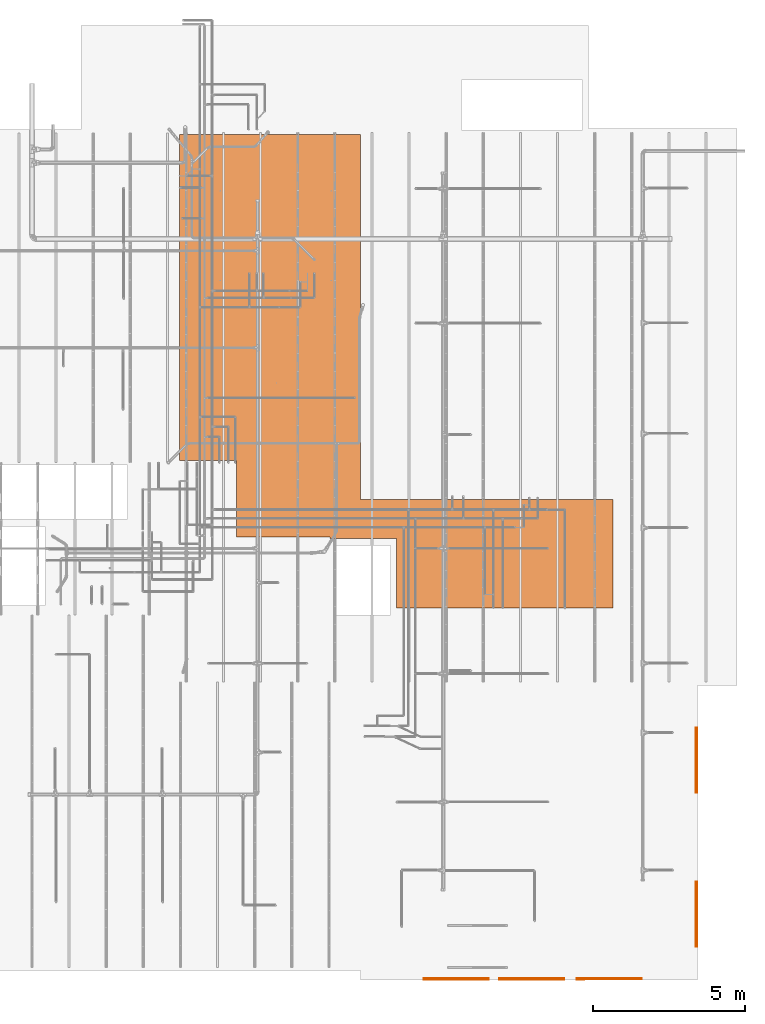
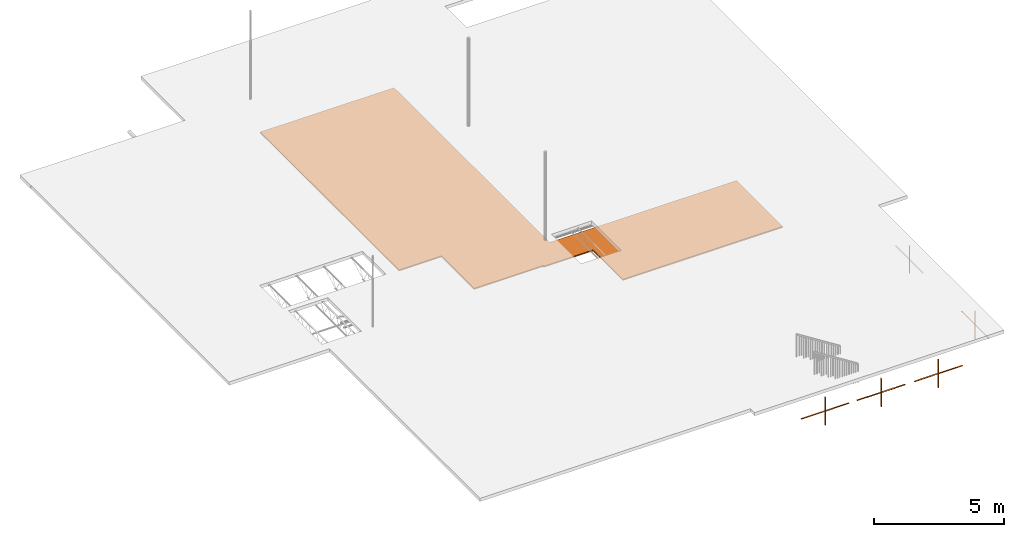
# One storey, part 171 of 173: 6 proxies.
"""IFC2X3 building model written with IfcOpenShell, lengths in feet."""

from ifc_helpers import new_model, entity, si_unit, converted_unit, derived_unit, direction, frame, origin, place, context, subcontext, project, spatial, polyline, outline, extrude, source, transform, mapped, material, material_list, type_object, type_shapes, element, save


model = new_model("IFC2X3")

# Units and contexts
model_context = context("Model", 3, precision=0.0001, world=origin(), true_north=direction((6.12303176911189e-17, 1.0)))
body_context = subcontext(model_context, "Body", "Model", "MODEL_VIEW")
ifc_project = project(units=[converted_unit("LENGTHUNIT", "FOOT", entity("IfcRatioMeasure", 0.3048), si_unit("LENGTHUNIT", "METRE"), dimensions=[1, 0, 0, 0, 0, 0, 0]), converted_unit("AREAUNIT", "SQUARE FOOT", entity("IfcRatioMeasure", 0.09290304), si_unit("AREAUNIT", "SQUARE_METRE"), dimensions=[2, 0, 0, 0, 0, 0, 0]), converted_unit("VOLUMEUNIT", "CUBIC FOOT", entity("IfcRatioMeasure", 0.028316846592), si_unit("VOLUMEUNIT", "CUBIC_METRE"), dimensions=[3, 0, 0, 0, 0, 0, 0]), converted_unit("PLANEANGLEUNIT", "DEGREE", entity("IfcRatioMeasure", 0.0174532925199433), si_unit("PLANEANGLEUNIT", "RADIAN"), dimensions=[0, 0, 0, 0, 0, 0, 0]), si_unit("MASSUNIT", "GRAM", prefix="KILO"), derived_unit("MASSDENSITYUNIT", [(si_unit("MASSUNIT", "GRAM", prefix="KILO"), 1), (si_unit("LENGTHUNIT", "METRE"), -3)]), si_unit("TIMEUNIT", "SECOND"), si_unit("FREQUENCYUNIT", "HERTZ"), si_unit("THERMODYNAMICTEMPERATUREUNIT", "DEGREE_CELSIUS"), derived_unit("THERMALTRANSMITTANCEUNIT", [(si_unit("MASSUNIT", "GRAM", prefix="KILO"), 1), (si_unit("THERMODYNAMICTEMPERATUREUNIT", "KELVIN"), -1), (si_unit("TIMEUNIT", "SECOND"), -3)]), derived_unit("VOLUMETRICFLOWRATEUNIT", [(si_unit("LENGTHUNIT", "METRE"), 3), (si_unit("TIMEUNIT", "SECOND"), -1)]), si_unit("ELECTRICCURRENTUNIT", "AMPERE"), si_unit("ELECTRICVOLTAGEUNIT", "VOLT"), si_unit("POWERUNIT", "WATT"), si_unit("FORCEUNIT", "NEWTON"), si_unit("ILLUMINANCEUNIT", "LUX"), si_unit("LUMINOUSFLUXUNIT", "LUMEN"), si_unit("LUMINOUSINTENSITYUNIT", "CANDELA"), derived_unit("USERDEFINED", [(si_unit("MASSUNIT", "GRAM", prefix="KILO"), -1), (si_unit("LENGTHUNIT", "METRE"), -2), (si_unit("TIMEUNIT", "SECOND"), 3), (si_unit("LUMINOUSFLUXUNIT", "LUMEN"), 1)]), derived_unit("LINEARVELOCITYUNIT", [(si_unit("LENGTHUNIT", "METRE"), 1), (si_unit("TIMEUNIT", "SECOND"), -1)]), si_unit("PRESSUREUNIT", "PASCAL"), derived_unit("USERDEFINED", [(si_unit("LENGTHUNIT", "METRE"), -2), (si_unit("MASSUNIT", "GRAM", prefix="KILO"), 1), (si_unit("TIMEUNIT", "SECOND"), -2)])], contexts=[model_context])

# Site, building, storey
site_placement = place(None, origin())
site = spatial("IfcSite", under=ifc_project, at=site_placement, CompositionType="ELEMENT")
building_placement = place(site_placement, origin())
building = spatial("IfcBuilding", under=site, at=building_placement, CompositionType="ELEMENT")
storey_placement = place(building_placement, frame((0.0, 0.0, 8.0)))
storey = spatial("IfcBuildingStorey", under=building, at=storey_placement, Name="REF", CompositionType="ELEMENT", Elevation=8.0)

# Proxies
ifc_material_1 = material(Name="Wood - Stained")
ifc_material_2 = material(Name="Clad - White 61141")
ifc_material_list_1 = material_list([ifc_material_1, ifc_material_2])
ifc_material_list_2 = material_list([ifc_material_1, ifc_material_2])
building_element_proxy_type_1 = type_object("IfcBuildingElementProxyType", Name="Muntin Pattern_2x2:Muntin Pattern_2x2", PredefinedType="NOTDEFINED", material=ifc_material_list_2)
shared_shape_1 = source(origin(), body_context, "Body", "SweptSolid", [
    extrude(outline(polyline([(-2.17187499999988, 0.0208333333334068), (-2.17187499999988, -0.020833333333254), (-0.0208333333333748, -0.020833333333254), (-0.0208333333333748, -3.50000000000014), (0.0208333333332913, -3.50000000000014), (0.0208333333332913, -0.0208333333332789), (2.17187500000003, -0.0208333333332789), (2.17187500000003, 0.0208333333333925), (0.020833333333302, 0.0208333333333925), (0.020833333333302, 3.49999999999985), (-0.0208333333333659, 3.49999999999985), (-0.0208333333333659, 0.0208333333334068), (-2.17187499999988, 0.0208333333334068)])), frame((24.7925312729019, -37.1900600419648, 9.91145833333324), z_axis=(0.0, -1.0, 0.0), x_axis=(0.0, 0.0, -1.0)), (0.0, 0.0, -1.0), 0.0416666666666572),
    extrude(outline(polyline([(-2.17187499999959, 0.0208333333334245), (-2.17187499999959, -0.0208333333332362), (-0.0208333333334654, -0.0208333333332362), (-0.0208333333334654, -3.50000000000014), (0.0208333333331918, -3.50000000000014), (0.0208333333331918, -0.0208333333332646), (2.17187500000009, -0.0208333333332646), (2.17187500000009, 0.020833333333389), (0.0208333333332167, 0.020833333333389), (0.0208333333332167, 3.49999999999985), (-0.0208333333334458, 3.49999999999985), (-0.0208333333334458, 0.0208333333334245), (-2.17187499999959, 0.0208333333334245)])), frame((24.7925312729019, -37.2942267086315, 9.91145833333295), z_axis=(0.0, -1.0, 0.0), x_axis=(0.0, 0.0, -1.0)), (0.0, 0.0, -1.0), 0.0416666666666501),
])
type_shapes(building_element_proxy_type_1, [shared_shape_1])
proxy_1_placement = place(storey_placement, frame((0.0, 0.0, -8.0)))
element("IfcBuildingElementProxy", 1, at=proxy_1_placement, inside=storey, type_object=building_element_proxy_type_1, material=ifc_material_list_1, ObjectType="Muntin Pattern_2x2 : Muntin Pattern_2x2:Muntin Pattern_2x2", context=body_context, shape_type="MappedRepresentation", body=[
    mapped(shared_shape_1, transform((0.0, 0.0, 0.0), scale=1.0)),
])
ifc_material_list_3 = material_list([ifc_material_1, ifc_material_2])
ifc_material_list_4 = material_list([ifc_material_1, ifc_material_2])
building_element_proxy_type_2 = type_object("IfcBuildingElementProxyType", Name="Muntin Pattern_2x2:Muntin Pattern_2x2", PredefinedType="NOTDEFINED", material=ifc_material_list_4)
shared_shape_2 = source(origin(), body_context, "Body", "SweptSolid", [
    extrude(outline(polyline([(-2.17187499999988, 0.020833333333421), (-2.17187499999988, -0.0208333333332433), (-0.0208333333333748, -0.0208333333332433), (-0.0208333333333748, -3.50000000000012), (0.0208333333332913, -3.50000000000012), (0.0208333333332913, -0.0208333333332718), (2.17187500000003, -0.0208333333332718), (2.17187500000003, 0.0208333333333997), (0.020833333333302, 0.0208333333333997), (0.020833333333302, 3.49999999999986), (-0.0208333333333659, 3.49999999999986), (-0.0208333333333659, 0.020833333333421), (-2.17187499999988, 0.020833333333421)])), frame((32.9591979395686, -37.1900600419649, 9.91145833333324), z_axis=(0.0, -1.0, 0.0), x_axis=(0.0, 0.0, -1.0)), (0.0, 0.0, -1.0), 0.0416666666666572),
    extrude(outline(polyline([(-2.17187499999959, 0.020833333333421), (-2.17187499999959, -0.0208333333332362), (-0.0208333333334654, -0.0208333333332362), (-0.0208333333334654, -3.50000000000014), (0.0208333333331918, -3.50000000000014), (0.0208333333331918, -0.0208333333332646), (2.17187500000009, -0.0208333333332646), (2.17187500000009, 0.0208333333333854), (0.0208333333332167, 0.0208333333333854), (0.0208333333332167, 3.49999999999984), (-0.0208333333334458, 3.49999999999984), (-0.0208333333334458, 0.020833333333421), (-2.17187499999959, 0.020833333333421)])), frame((32.9591979395686, -37.2942267086316, 9.91145833333295), z_axis=(0.0, -1.0, 0.0), x_axis=(0.0, 0.0, -1.0)), (0.0, 0.0, -1.0), 0.0416666666666501),
])
type_shapes(building_element_proxy_type_2, [shared_shape_2])
proxy_2_placement = place(storey_placement, frame((0.0, 0.0, -8.0)))
element("IfcBuildingElementProxy", 2, at=proxy_2_placement, inside=storey, type_object=building_element_proxy_type_2, material=ifc_material_list_3, ObjectType="Muntin Pattern_2x2 : Muntin Pattern_2x2:Muntin Pattern_2x2", context=body_context, shape_type="MappedRepresentation", body=[
    mapped(shared_shape_2, transform((0.0, 0.0, 0.0), scale=1.0)),
])
ifc_material_list_5 = material_list([ifc_material_1, ifc_material_2])
ifc_material_list_6 = material_list([ifc_material_1, ifc_material_2])
building_element_proxy_type_3 = type_object("IfcBuildingElementProxyType", Name="Muntin Pattern_2x2:Muntin Pattern_2x2", PredefinedType="NOTDEFINED", material=ifc_material_list_6)
shared_shape_3 = source(origin(), body_context, "Body", "SweptSolid", [
    extrude(outline(polyline([(-2.17187499999988, 0.020833333333421), (-2.17187499999988, -0.0208333333332433), (-0.0208333333333748, -0.0208333333332433), (-0.0208333333333748, -3.50000000000013), (0.0208333333332913, -3.50000000000013), (0.0208333333332913, -0.0208333333332718), (2.17187500000003, -0.0208333333332718), (2.17187500000003, 0.0208333333333997), (0.020833333333302, 0.0208333333333997), (0.020833333333302, 3.49999999999986), (-0.0208333333333659, 3.49999999999986), (-0.0208333333333659, 0.020833333333421), (-2.17187499999988, 0.020833333333421)])), frame((41.2925312729019, -37.1900600419649, 9.91145833333324), z_axis=(0.0, -1.0, 0.0), x_axis=(0.0, 0.0, -1.0)), (0.0, 0.0, -1.0), 0.0416666666666572),
    extrude(outline(polyline([(-2.17187499999959, 0.020833333333421), (-2.17187499999959, -0.0208333333332362), (-0.0208333333334654, -0.0208333333332362), (-0.0208333333334654, -3.50000000000014), (0.0208333333331918, -3.50000000000014), (0.0208333333331918, -0.0208333333332646), (2.17187500000009, -0.0208333333332646), (2.17187500000009, 0.0208333333333854), (0.0208333333332167, 0.0208333333333854), (0.0208333333332167, 3.49999999999984), (-0.0208333333334458, 3.49999999999984), (-0.0208333333334458, 0.020833333333421), (-2.17187499999959, 0.020833333333421)])), frame((41.2925312729019, -37.2942267086316, 9.91145833333295), z_axis=(0.0, -1.0, 0.0), x_axis=(0.0, 0.0, -1.0)), (0.0, 0.0, -1.0), 0.0416666666666501),
])
type_shapes(building_element_proxy_type_3, [shared_shape_3])
proxy_3_placement = place(storey_placement, frame((0.0, 0.0, -8.0)))
element("IfcBuildingElementProxy", 3, at=proxy_3_placement, inside=storey, type_object=building_element_proxy_type_3, material=ifc_material_list_5, ObjectType="Muntin Pattern_2x2 : Muntin Pattern_2x2:Muntin Pattern_2x2", context=body_context, shape_type="MappedRepresentation", body=[
    mapped(shared_shape_3, transform((0.0, 0.0, 0.0), scale=1.0)),
])
ifc_material_list_7 = material_list([ifc_material_1, ifc_material_2])
ifc_material_list_8 = material_list([ifc_material_1, ifc_material_2])
building_element_proxy_type_4 = type_object("IfcBuildingElementProxyType", Name="Muntin Pattern_2x2:Muntin Pattern_2x2", PredefinedType="NOTDEFINED", material=ifc_material_list_8)
shared_shape_4 = source(origin(), body_context, "Body", "SweptSolid", [
    extrude(outline(polyline([(-0.0208333333334103, -2.17187499999989), (0.0208333333332504, -2.17187499999989), (0.0208333333332504, -0.0208333333333783), (3.50000000000013, -0.0208333333333783), (3.50000000000013, 0.0208333333332877), (0.0208333333332753, 0.0208333333332877), (0.0208333333332753, 2.17187500000002), (-0.0208333333333961, 2.17187500000002), (-0.0208333333333961, 0.0208333333332984), (-3.49999999999985, 0.0208333333332984), (-3.49999999999985, -0.0208333333333695), (-0.0208333333334103, -0.0208333333333695), (-0.0208333333334103, -2.17187499999989)])), frame((50.6098326025058, -30.2753340999121, 9.91145833333323), z_axis=(1.0, 0.0, 0.0), x_axis=(0.0, -1.0, 0.0)), (0.0, 0.0, 1.0), 0.0416666666666572),
    extrude(outline(polyline([(-0.020833333333421, -2.17187499999959), (0.0208333333332398, -2.17187499999959), (0.0208333333332398, -0.0208333333334654), (3.50000000000014, -0.0208333333334654), (3.50000000000014, 0.0208333333331918), (0.0208333333332682, 0.0208333333331918), (0.0208333333332682, 2.17187500000009), (-0.0208333333333854, 2.17187500000009), (-0.0208333333333854, 0.0208333333332167), (-3.49999999999984, 0.0208333333332167), (-3.49999999999984, -0.0208333333334458), (-0.020833333333421, -0.0208333333334458), (-0.020833333333421, -2.17187499999959)])), frame((50.7139992691725, -30.2753340999121, 9.91145833333295), z_axis=(1.0, 0.0, 0.0), x_axis=(0.0, -1.0, 0.0)), (0.0, 0.0, 1.0), 0.0416666666666501),
])
type_shapes(building_element_proxy_type_4, [shared_shape_4])
proxy_4_placement = place(storey_placement, frame((0.0, 0.0, -8.0)))
element("IfcBuildingElementProxy", 4, at=proxy_4_placement, inside=storey, type_object=building_element_proxy_type_4, material=ifc_material_list_7, ObjectType="Muntin Pattern_2x2 : Muntin Pattern_2x2:Muntin Pattern_2x2", context=body_context, shape_type="MappedRepresentation", body=[
    mapped(shared_shape_4, transform((0.0, 0.0, 0.0), scale=1.0)),
])
ifc_material_list_9 = material_list([ifc_material_1, ifc_material_2])
ifc_material_list_10 = material_list([ifc_material_1, ifc_material_2])
building_element_proxy_type_5 = type_object("IfcBuildingElementProxyType", Name="Muntin Pattern_2x2:Muntin Pattern_2x2", PredefinedType="NOTDEFINED", material=ifc_material_list_10)
shared_shape_5 = source(origin(), body_context, "Body", "SweptSolid", [
    extrude(outline(polyline([(-0.0208333333334121, -2.17187499999989), (0.0208333333332487, -2.17187499999989), (0.0208333333332487, -0.0208333333333783), (3.50000000000013, -0.0208333333333783), (3.50000000000013, 0.0208333333332877), (0.0208333333332771, 0.0208333333332877), (0.0208333333332771, 2.17187500000002), (-0.0208333333333961, 2.17187500000002), (-0.0208333333333961, 0.0208333333332984), (-3.49999999999985, 0.0208333333332984), (-3.49999999999985, -0.0208333333333695), (-0.0208333333334121, -0.0208333333333695), (-0.0208333333334121, -2.17187499999989)])), frame((50.6098326025058, -13.6692267086315, 9.91145833333323), z_axis=(1.0, 0.0, 0.0), x_axis=(0.0, -1.0, 0.0)), (0.0, 0.0, 1.0), 0.0416666666666572),
    extrude(outline(polyline([(-0.0208333333334174, -2.17187499999959), (0.0208333333332433, -2.17187499999959), (0.0208333333332433, -0.0208333333334654), (3.50000000000014, -0.0208333333334654), (3.50000000000014, 0.0208333333331918), (0.0208333333332718, 0.0208333333331918), (0.0208333333332718, 2.17187500000009), (-0.0208333333333801, 2.17187500000009), (-0.0208333333333801, 0.0208333333332167), (-3.49999999999984, 0.0208333333332167), (-3.49999999999984, -0.0208333333334458), (-0.0208333333334174, -0.0208333333334458), (-0.0208333333334174, -2.17187499999959)])), frame((50.7139992691726, -13.6692267086315, 9.91145833333295), z_axis=(1.0, 0.0, 0.0), x_axis=(0.0, -1.0, 0.0)), (0.0, 0.0, 1.0), 0.0416666666666501),
])
type_shapes(building_element_proxy_type_5, [shared_shape_5])
proxy_5_placement = place(storey_placement, frame((0.0, 0.0, -8.0)))
element("IfcBuildingElementProxy", 5, at=proxy_5_placement, inside=storey, type_object=building_element_proxy_type_5, material=ifc_material_list_9, ObjectType="Muntin Pattern_2x2 : Muntin Pattern_2x2:Muntin Pattern_2x2", context=body_context, shape_type="MappedRepresentation", body=[
    mapped(shared_shape_5, transform((0.0, 0.0, 0.0), scale=1.0)),
])
ifc_material_3 = material(Name="Default")
building_element_proxy_type_6 = type_object("IfcBuildingElementProxyType", PredefinedType="NOTDEFINED", material=ifc_material_3)
shared_shape_6 = source(origin(), body_context, "Body", "SweptSolid", [
    extrude(outline(polyline([(-0.289495650155441, -12.5055523227996), (7.96050434984455, -12.5055523227996), (7.96050434984455, -2.43424368664562), (8.12717101651121, -2.43424368664562), (8.12717101651121, 4.73242298002106), (15.6271710165112, 4.73242298002106), (15.6271710165112, 28.051739343867), (3.94226991744389, 28.051739343867), (3.94226991744389, 0.838269341690147), (-35.3676206501554, 0.838269341690147), (-35.3676206501554, -18.682635656133), (-0.289495650155441, -18.682635656133), (-0.289495650155441, -12.5055523227996)])), frame((13.6518432586389, 18.3746109745463, 8.0), z_axis=(0.0, 0.0, 1.0), x_axis=(0.0, -1.0, 0.0)), (0.0, 0.0, 1.0), 0.187499999999999),
])
type_shapes(building_element_proxy_type_6, [shared_shape_6])
proxy_6_placement = place(storey_placement, frame((0.0, 0.0, -8.0)))
element("IfcBuildingElementProxy", 6, at=proxy_6_placement, inside=storey, type_object=building_element_proxy_type_6, material=ifc_material_3, context=body_context, shape_type="MappedRepresentation", body=[
    mapped(shared_shape_6, transform((0.0, 0.0, 0.0), scale=1.0)),
])

save(model, "model.ifc")
